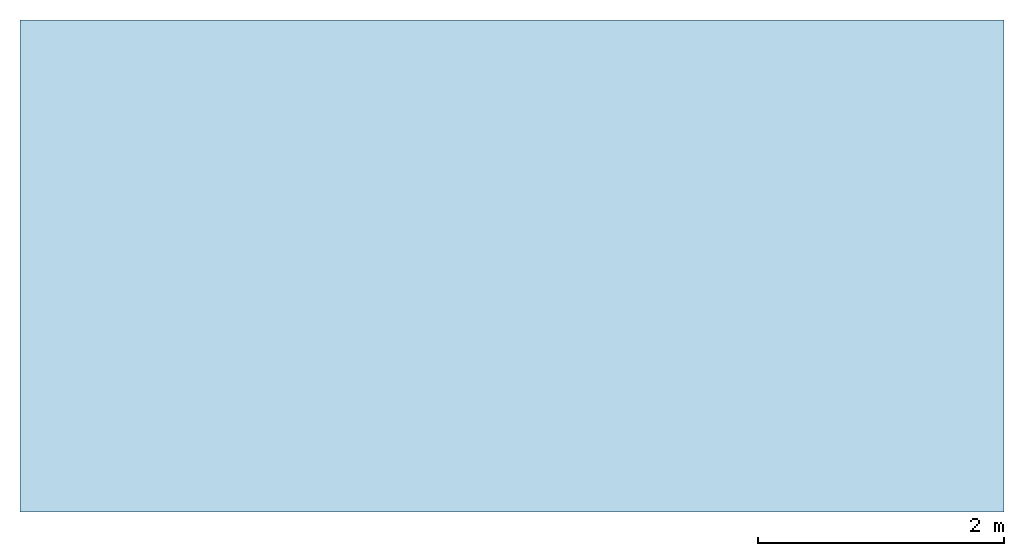
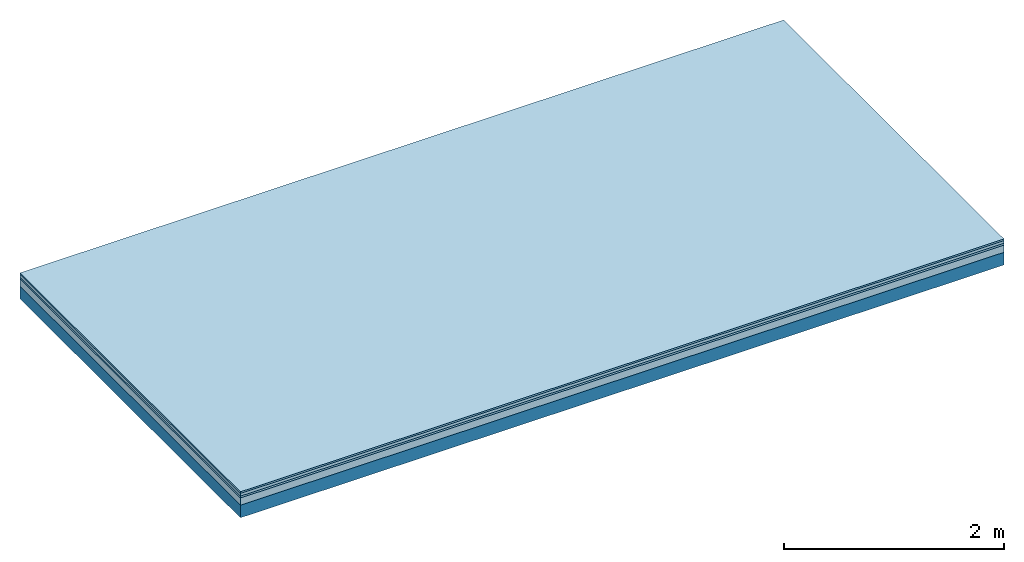
# One storey: 4 plates, 1 member, 1 element without a shape of its own.
"""IFC4 building model written with IfcOpenShell, lengths in metres."""

import ifcopenshell
import ifcopenshell.guid

model = None  # the IFC model being written
_history = None  # IfcOwnerHistory: only IFC2X3 demands one
_inside = {}  # id of a spatial element -> (the spatial element, [elements in it])
_under = {}  # id of a project, library or spatial element -> (it, [spatial elements below it])
_declared = {}  # id of a project -> (the project, [libraries it declares])
_typed = {}  # id of a type object -> (the type object, [elements of that type])
_made_of = {}  # id of a material, layer set ... -> (it, [elements and type objects made of it])


def new_model(schema):
    """Start an empty IFC model of exactly this schema.

    Asked for "IFC4X3", IfcOpenShell would pick the latest addendum, in which some entities
    have other attributes; the version numbers below select the first issue.
    IFC2X3 requires an IfcOwnerHistory on every rooted entity: one is made here for all.
    """
    global model, _history
    if schema == "IFC4X3":
        model = ifcopenshell.file(schema_version=(4, 3, 0, 0))
    else:
        model = ifcopenshell.file(schema=schema)
    _inside.clear()
    _under.clear()
    _declared.clear()
    _typed.clear()
    _made_of.clear()
    _history = None
    if model.schema == "IFC2X3":
        org = make("IfcOrganization", Name="unknown")
        user = make(
            "IfcPersonAndOrganization",
            ThePerson=make("IfcPerson", FamilyName="unknown"),
            TheOrganization=org,
        )
        app = make(
            "IfcApplication",
            ApplicationDeveloper=org,
            Version="unknown",
            ApplicationFullName="unknown",
            ApplicationIdentifier="unknown",
        )
        _history = make(
            "IfcOwnerHistory",
            OwningUser=user,
            OwningApplication=app,
            ChangeAction="ADDED",
            CreationDate=0,
        )
    return model


def make(cls, **values):
    """One entity of the class cls with the attributes given. An attribute that is None is left unset."""
    return model.create_entity(
        cls, **{name: value for name, value in values.items() if value is not None}
    )


def rooted(cls, **values):
    """An entity with a GlobalId (a new one), such as an element, a storey or a relation."""
    return make(cls, GlobalId=ifcopenshell.guid.new(), OwnerHistory=_history, **values)


def si_unit(unit_type, name, prefix=None):
    """IfcSIUnit, for example si_unit("LENGTHUNIT", "METRE", prefix="MILLI")."""
    return make("IfcSIUnit", UnitType=unit_type, Prefix=prefix, Name=name)


def derived_unit(unit_type, elements):
    """IfcDerivedUnit: a product of units, each with its exponent."""
    return make(
        "IfcDerivedUnit",
        Elements=[
            make("IfcDerivedUnitElement", Unit=unit, Exponent=power)
            for unit, power in elements
        ],
        UnitType=unit_type,
    )


def assignment(units):
    """IfcUnitAssignment: the units of a project."""
    return None if units is None else make("IfcUnitAssignment", Units=units)


def point(xyz):
    """IfcCartesianPoint."""
    return None if xyz is None else make("IfcCartesianPoint", Coordinates=xyz)


def direction(xyz):
    """IfcDirection."""
    return None if xyz is None else make("IfcDirection", DirectionRatios=xyz)


def frame(location, z_axis=None, x_axis=None):
    """IfcAxis2Placement3D, a coordinate frame: its origin and axes. An axis left out is left unset."""
    return make(
        "IfcAxis2Placement3D",
        Location=point(location),
        Axis=direction(z_axis),
        RefDirection=direction(x_axis),
    )


def frame_2d(location, x_axis=None):
    """IfcAxis2Placement2D, a coordinate frame in the plane: its origin and x axis."""
    return make(
        "IfcAxis2Placement2D", Location=point(location), RefDirection=direction(x_axis)
    )


def origin():
    """The frame at (0, 0, 0) with its axes left unset."""
    return frame((0.0, 0.0, 0.0))


def origin_with_axes():
    """The frame at (0, 0, 0) with the z axis (0, 0, 1) and the x axis (1, 0, 0) written out."""
    return frame((0.0, 0.0, 0.0), z_axis=(0.0, 0.0, 1.0), x_axis=(1.0, 0.0, 0.0))


def place(relative_to, where):
    """IfcLocalPlacement: puts the frame where relative to a parent placement (None: the world)."""
    return make(
        "IfcLocalPlacement", PlacementRelTo=relative_to, RelativePlacement=where
    )


def context(
    kind, dimensions, precision=None, world=None, true_north=None, identifier=None
):
    """IfcGeometricRepresentationContext, for example the 3D "Model" context."""
    return make(
        "IfcGeometricRepresentationContext",
        ContextIdentifier=identifier,
        ContextType=kind,
        CoordinateSpaceDimension=dimensions,
        Precision=precision,
        WorldCoordinateSystem=world,
        TrueNorth=true_north,
    )


def project(units=None, contexts=None):
    """IfcProject with its units and contexts."""
    return rooted(
        "IfcProject",
        Name="project",
        RepresentationContexts=contexts,
        UnitsInContext=assignment(units),
    )


def spatial(cls, under=None, at=None, **own):
    """A site, building, storey or space (cls), placed at a placement, below another one or the project."""
    s = rooted(cls, ObjectPlacement=at, **own)
    if under is not None:
        _under.setdefault(under.id(), (under, []))[1].append(s)
    return s


def profile(cls, at=None, kind="AREA", **sizes):
    """A parametric profile (cls). Its sizes go by their IFC names, for example OverallWidth=200.0."""
    return make(cls, ProfileType=kind, Position=at, **sizes)


def rectangle(**sizes):
    """IfcRectangleProfileDef."""
    return profile("IfcRectangleProfileDef", **sizes)


def extrude(swept, where, along, depth):
    """IfcExtrudedAreaSolid: the profile swept, set in the frame where, extruded along a direction by depth."""
    return make(
        "IfcExtrudedAreaSolid",
        SweptArea=swept,
        Position=where,
        ExtrudedDirection=direction(along),
        Depth=depth,
    )


def shape(context_of_items, identifier, shape_type, items):
    """IfcShapeRepresentation: the items that make up one representation, for example the "Body"."""
    return make(
        "IfcShapeRepresentation",
        ContextOfItems=context_of_items,
        RepresentationIdentifier=identifier,
        RepresentationType=shape_type,
        Items=items,
    )


def material(Name=None, Category=None):
    """IfcMaterial."""
    return make("IfcMaterial", Name=Name, Category=Category)


def layer(
    of_material, thickness, ventilated=None, Name=None, Category=None, Priority=None
):
    """IfcMaterialLayer: one layer of a wall or slab, of a material (None: an air gap)."""
    return make(
        "IfcMaterialLayer",
        Material=of_material,
        LayerThickness=thickness,
        IsVentilated=ventilated,
        Name=Name,
        Category=Category,
        Priority=Priority,
    )


def layer_set(layers, Name=None):
    """IfcMaterialLayerSet."""
    return make("IfcMaterialLayerSet", MaterialLayers=layers, LayerSetName=Name)


def made_of(thing, what):
    """Note that an element or type object is made of a material, layer set ...; save() writes the relation."""
    if what is not None:
        _made_of.setdefault(what.id(), (what, []))[1].append(thing)
    return thing


def type_object(cls, material=None, **own):
    """A type object (cls), such as IfcWallType, which elements share."""
    return made_of(rooted(cls, **own), material)


def element(
    cls,
    number,
    at=None,
    inside=None,
    cuts=None,
    type_object=None,
    material=None,
    context=None,
    identifier="Body",
    shape_type=None,
    held_by="IfcProductDefinitionShape",
    body=None,
    shapes=None,
    **own,
):
    """One element of the class cls, such as IfcWall. Its Tag is "e" and its number.

    at: its placement. inside: the storey or other place that contains it. cuts: it is an
    opening in that element (IfcRelVoidsElement). A single representation is given by context,
    identifier, shape_type and body (its items); several are given by shapes. held_by: the class
    of the entity that holds the representations. save() writes the other relations.
    """
    e = rooted(cls, Tag="e%d" % number, ObjectPlacement=at, **own)
    if body is not None:
        shapes = [shape(context, identifier, shape_type, body)]
    if shapes is not None:
        e.Representation = make(held_by, Representations=shapes)
    if inside is not None:
        _inside.setdefault(inside.id(), (inside, []))[1].append(e)
    if cuts is not None:
        rooted(
            "IfcRelVoidsElement", RelatingBuildingElement=cuts, RelatedOpeningElement=e
        )
    if type_object is not None:
        _typed.setdefault(type_object.id(), (type_object, []))[1].append(e)
    return made_of(e, material)


def aggregate(whole, parts):
    """IfcRelAggregates: a whole, such as a stair, and the parts it consists of."""
    return rooted("IfcRelAggregates", RelatingObject=whole, RelatedObjects=parts)


def save(model, path):
    """Write the relations noted so far, then the file.

    IfcRelAggregates (storeys below a building ...), IfcRelContainedInSpatialStructure (elements
    in a storey), IfcRelDefinesByType, IfcRelAssociatesMaterial and IfcRelDeclares: one each for
    every whole, place, type object, material and project.
    """
    for whole, parts in _under.values():
        aggregate(whole, parts)
    for where, things in _inside.values():
        rooted(
            "IfcRelContainedInSpatialStructure",
            RelatedElements=things,
            RelatingStructure=where,
        )
    for kind, things in _typed.values():
        rooted("IfcRelDefinesByType", RelatedObjects=things, RelatingType=kind)
    for what, things in _made_of.values():
        rooted("IfcRelAssociatesMaterial", RelatedObjects=things, RelatingMaterial=what)
    for by, libraries in _declared.values():
        rooted("IfcRelDeclares", RelatingContext=by, RelatedDefinitions=libraries)
    model.write(path)


model = new_model("IFC4")

# Units and contexts
plan_context = context("Plan", 3, precision=1e-05, world=origin(), true_north=direction((0.0, 1.0)))
model_context = context("Model", 3, precision=1e-05, world=origin(), true_north=direction((0.0, 1.0)))
ifc_project = project(units=[si_unit("LENGTHUNIT", "METRE"), derived_unit("SOUNDPRESSUREUNIT", [(si_unit("PRESSUREUNIT", "PASCAL", prefix="MICRO"), 0)]), si_unit("ENERGYUNIT", "JOULE", prefix="MEGA"), si_unit("MASSUNIT", "GRAM", prefix="KILO"), derived_unit("THERMALTRANSMITTANCEUNIT", [(si_unit("POWERUNIT", "WATT"), 1), (si_unit("AREAUNIT", "SQUARE_METRE"), -1), (si_unit("THERMODYNAMICTEMPERATUREUNIT", "KELVIN"), -1)]), derived_unit("AREADENSITYUNIT", [(si_unit("MASSUNIT", "GRAM", prefix="KILO"), 1), (si_unit("AREAUNIT", "SQUARE_METRE"), -1)]), derived_unit("USERDEFINED", [(si_unit("ENERGYUNIT", "JOULE", prefix="MEGA"), 1), (si_unit("AREAUNIT", "SQUARE_METRE"), -1)])], contexts=[plan_context, model_context])

# Site, building, storey
site = spatial("IfcSite", under=ifc_project)
building_placement = place(None, origin())
building = spatial("IfcBuilding", under=site, at=building_placement)
storey_placement = place(building_placement, origin())
storey = spatial("IfcBuildingStorey", under=building, at=storey_placement)

# Slab, member, plates
ifc_material_1 = material(Name="Floor heating system Therm38 longitudinal", Category="03.007")
ifc_layer_1 = layer(ifc_material_1, 0.018, Name="Flooring")
ifc_material_2 = material(Name="Phone Star TRI", Category="03.013")
ifc_layer_2 = layer(ifc_material_2, 0.03, Name="On-material")
ifc_material_3 = material(Name="EP3")
ifc_layer_3 = layer(ifc_material_3, 0.02, Name="Impact sound insulation")
ifc_material_4 = material(Category="03.011")
ifc_layer_4 = layer(ifc_material_4, 0.08, Name="on Supporting structure")
ifc_material_5 = material(Name="no composite action")
ifc_layer_5 = layer(ifc_material_5, 0.0, Name="Bond")
ifc_layer_6 = layer(None, 0.14, Name="Supporting structure")
ifc_layer_set = layer_set([ifc_layer_1, ifc_layer_2, ifc_layer_3, ifc_layer_4, ifc_layer_5, ifc_layer_6])
slab_type = type_object("IfcSlabType", Name="A2451", PredefinedType="NOTDEFINED", material=ifc_layer_set)
slab_placement = place(None, frame((0.0, 0.0, 0.0), z_axis=(0.0, 0.0, -1.0), x_axis=(1.0, 0.0, 0.0)))
slab = element("IfcSlab", 1, at=slab_placement, inside=storey, type_object=slab_type, material=ifc_layer_set, Name="Slab #1")
ifc_material_6 = material()
member_placement = place(slab_placement, origin())
member = element("IfcMember", 2, at=member_placement, material=ifc_material_6, Name="Supporting structure", context=plan_context, shape_type="SweptSolid", body=[
    extrude(rectangle(XDim=1.0, YDim=0.14, at=frame_2d((0.5, 0.07), x_axis=(1.0, 0.0))), frame((0.0, 4.0, 0.148), z_axis=(0.0, -1.0, 0.0), x_axis=(1.0, 0.0, 0.0)), (0.0, 0.0, 1.0), 4.0),
    extrude(rectangle(XDim=1.0, YDim=0.14, at=frame_2d((0.5, 0.07), x_axis=(1.0, 0.0))), frame((1.0, 4.0, 0.148), z_axis=(0.0, -1.0, 0.0), x_axis=(1.0, 0.0, 0.0)), (0.0, 0.0, 1.0), 4.0),
    extrude(rectangle(XDim=1.0, YDim=0.14, at=frame_2d((0.5, 0.07), x_axis=(1.0, 0.0))), frame((2.0, 4.0, 0.148), z_axis=(0.0, -1.0, 0.0), x_axis=(1.0, 0.0, 0.0)), (0.0, 0.0, 1.0), 4.0),
    extrude(rectangle(XDim=1.0, YDim=0.14, at=frame_2d((0.5, 0.07), x_axis=(1.0, 0.0))), frame((3.0, 4.0, 0.148), z_axis=(0.0, -1.0, 0.0), x_axis=(1.0, 0.0, 0.0)), (0.0, 0.0, 1.0), 4.0),
    extrude(rectangle(XDim=1.0, YDim=0.14, at=frame_2d((0.5, 0.07), x_axis=(1.0, 0.0))), frame((4.0, 4.0, 0.148), z_axis=(0.0, -1.0, 0.0), x_axis=(1.0, 0.0, 0.0)), (0.0, 0.0, 1.0), 4.0),
    extrude(rectangle(XDim=1.0, YDim=0.14, at=frame_2d((0.5, 0.07), x_axis=(1.0, 0.0))), frame((5.0, 4.0, 0.148), z_axis=(0.0, -1.0, 0.0), x_axis=(1.0, 0.0, 0.0)), (0.0, 0.0, 1.0), 4.0),
    extrude(rectangle(XDim=1.0, YDim=0.14, at=frame_2d((0.5, 0.07), x_axis=(1.0, 0.0))), frame((6.0, 4.0, 0.148), z_axis=(0.0, -1.0, 0.0), x_axis=(1.0, 0.0, 0.0)), (0.0, 0.0, 1.0), 4.0),
    extrude(rectangle(XDim=1.0, YDim=0.14, at=frame_2d((0.5, 0.07), x_axis=(1.0, 0.0))), frame((7.0, 4.0, 0.148), z_axis=(0.0, -1.0, 0.0), x_axis=(1.0, 0.0, 0.0)), (0.0, 0.0, 1.0), 4.0),
])
plate_1_placement = place(slab_placement, origin())
plate_1 = element("IfcPlate", 3, at=plate_1_placement, material=ifc_material_1, Name="Flooring", context=plan_context, shape_type="SweptSolid", body=[
    extrude(rectangle(XDim=8.0, YDim=4.0, at=frame_2d((4.0, 2.0), x_axis=(1.0, 0.0))), origin_with_axes(), (0.0, 0.0, 1.0), 0.018),
])
plate_2_placement = place(slab_placement, origin())
plate_2 = element("IfcPlate", 4, at=plate_2_placement, material=ifc_material_2, Name="On-material", context=plan_context, shape_type="SweptSolid", body=[
    extrude(rectangle(XDim=8.0, YDim=4.0, at=frame_2d((4.0, 2.0), x_axis=(1.0, 0.0))), frame((0.0, 0.0, 0.018), z_axis=(0.0, 0.0, 1.0), x_axis=(1.0, 0.0, 0.0)), (0.0, 0.0, 1.0), 0.03),
])
plate_3_placement = place(slab_placement, origin())
plate_3 = element("IfcPlate", 5, at=plate_3_placement, material=ifc_material_3, Name="Impact sound insulation", context=plan_context, shape_type="SweptSolid", body=[
    extrude(rectangle(XDim=8.0, YDim=4.0, at=frame_2d((4.0, 2.0), x_axis=(1.0, 0.0))), frame((0.0, 0.0, 0.048), z_axis=(0.0, 0.0, 1.0), x_axis=(1.0, 0.0, 0.0)), (0.0, 0.0, 1.0), 0.02),
])
plate_4_placement = place(slab_placement, origin())
plate_4 = element("IfcPlate", 6, at=plate_4_placement, material=ifc_material_4, Name="on Supporting structure", context=plan_context, shape_type="SweptSolid", body=[
    extrude(rectangle(XDim=8.0, YDim=4.0, at=frame_2d((4.0, 2.0), x_axis=(1.0, 0.0))), frame((0.0, 0.0, 0.068), z_axis=(0.0, 0.0, 1.0), x_axis=(1.0, 0.0, 0.0)), (0.0, 0.0, 1.0), 0.08),
])
aggregate(slab, [plate_1, plate_2, plate_3, plate_4, member])

save(model, "model.ifc")
